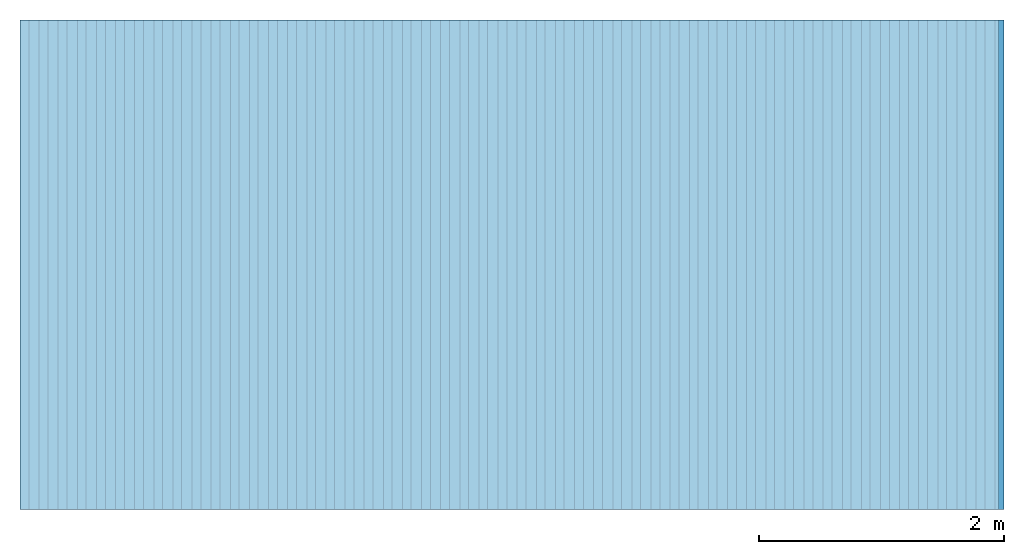
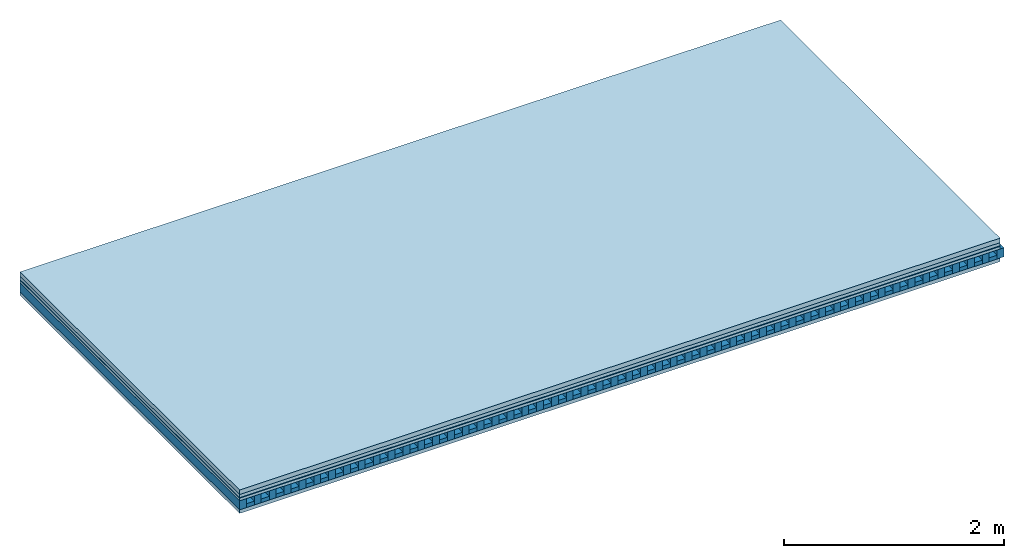
# One storey: 5 plates, 2 members, 1 element without a shape of its own.
"""IFC4 building model written with IfcOpenShell, lengths in metres."""

import ifcopenshell
import ifcopenshell.guid

model = None  # the IFC model being written
_history = None  # IfcOwnerHistory: only IFC2X3 demands one
_inside = {}  # id of a spatial element -> (the spatial element, [elements in it])
_under = {}  # id of a project, library or spatial element -> (it, [spatial elements below it])
_declared = {}  # id of a project -> (the project, [libraries it declares])
_typed = {}  # id of a type object -> (the type object, [elements of that type])
_made_of = {}  # id of a material, layer set ... -> (it, [elements and type objects made of it])


def new_model(schema):
    """Start an empty IFC model of exactly this schema.

    Asked for "IFC4X3", IfcOpenShell would pick the latest addendum, in which some entities
    have other attributes; the version numbers below select the first issue.
    IFC2X3 requires an IfcOwnerHistory on every rooted entity: one is made here for all.
    """
    global model, _history
    if schema == "IFC4X3":
        model = ifcopenshell.file(schema_version=(4, 3, 0, 0))
    else:
        model = ifcopenshell.file(schema=schema)
    _inside.clear()
    _under.clear()
    _declared.clear()
    _typed.clear()
    _made_of.clear()
    _history = None
    if model.schema == "IFC2X3":
        org = make("IfcOrganization", Name="unknown")
        user = make(
            "IfcPersonAndOrganization",
            ThePerson=make("IfcPerson", FamilyName="unknown"),
            TheOrganization=org,
        )
        app = make(
            "IfcApplication",
            ApplicationDeveloper=org,
            Version="unknown",
            ApplicationFullName="unknown",
            ApplicationIdentifier="unknown",
        )
        _history = make(
            "IfcOwnerHistory",
            OwningUser=user,
            OwningApplication=app,
            ChangeAction="ADDED",
            CreationDate=0,
        )
    return model


def make(cls, **values):
    """One entity of the class cls with the attributes given. An attribute that is None is left unset."""
    return model.create_entity(
        cls, **{name: value for name, value in values.items() if value is not None}
    )


def rooted(cls, **values):
    """An entity with a GlobalId (a new one), such as an element, a storey or a relation."""
    return make(cls, GlobalId=ifcopenshell.guid.new(), OwnerHistory=_history, **values)


def si_unit(unit_type, name, prefix=None):
    """IfcSIUnit, for example si_unit("LENGTHUNIT", "METRE", prefix="MILLI")."""
    return make("IfcSIUnit", UnitType=unit_type, Prefix=prefix, Name=name)


def derived_unit(unit_type, elements):
    """IfcDerivedUnit: a product of units, each with its exponent."""
    return make(
        "IfcDerivedUnit",
        Elements=[
            make("IfcDerivedUnitElement", Unit=unit, Exponent=power)
            for unit, power in elements
        ],
        UnitType=unit_type,
    )


def assignment(units):
    """IfcUnitAssignment: the units of a project."""
    return None if units is None else make("IfcUnitAssignment", Units=units)


def point(xyz):
    """IfcCartesianPoint."""
    return None if xyz is None else make("IfcCartesianPoint", Coordinates=xyz)


def direction(xyz):
    """IfcDirection."""
    return None if xyz is None else make("IfcDirection", DirectionRatios=xyz)


def frame(location, z_axis=None, x_axis=None):
    """IfcAxis2Placement3D, a coordinate frame: its origin and axes. An axis left out is left unset."""
    return make(
        "IfcAxis2Placement3D",
        Location=point(location),
        Axis=direction(z_axis),
        RefDirection=direction(x_axis),
    )


def frame_2d(location, x_axis=None):
    """IfcAxis2Placement2D, a coordinate frame in the plane: its origin and x axis."""
    return make(
        "IfcAxis2Placement2D", Location=point(location), RefDirection=direction(x_axis)
    )


def origin():
    """The frame at (0, 0, 0) with its axes left unset."""
    return frame((0.0, 0.0, 0.0))


def origin_with_axes():
    """The frame at (0, 0, 0) with the z axis (0, 0, 1) and the x axis (1, 0, 0) written out."""
    return frame((0.0, 0.0, 0.0), z_axis=(0.0, 0.0, 1.0), x_axis=(1.0, 0.0, 0.0))


def place(relative_to, where):
    """IfcLocalPlacement: puts the frame where relative to a parent placement (None: the world)."""
    return make(
        "IfcLocalPlacement", PlacementRelTo=relative_to, RelativePlacement=where
    )


def context(
    kind, dimensions, precision=None, world=None, true_north=None, identifier=None
):
    """IfcGeometricRepresentationContext, for example the 3D "Model" context."""
    return make(
        "IfcGeometricRepresentationContext",
        ContextIdentifier=identifier,
        ContextType=kind,
        CoordinateSpaceDimension=dimensions,
        Precision=precision,
        WorldCoordinateSystem=world,
        TrueNorth=true_north,
    )


def project(units=None, contexts=None):
    """IfcProject with its units and contexts."""
    return rooted(
        "IfcProject",
        Name="project",
        RepresentationContexts=contexts,
        UnitsInContext=assignment(units),
    )


def spatial(cls, under=None, at=None, **own):
    """A site, building, storey or space (cls), placed at a placement, below another one or the project."""
    s = rooted(cls, ObjectPlacement=at, **own)
    if under is not None:
        _under.setdefault(under.id(), (under, []))[1].append(s)
    return s


def profile(cls, at=None, kind="AREA", **sizes):
    """A parametric profile (cls). Its sizes go by their IFC names, for example OverallWidth=200.0."""
    return make(cls, ProfileType=kind, Position=at, **sizes)


def rectangle(**sizes):
    """IfcRectangleProfileDef."""
    return profile("IfcRectangleProfileDef", **sizes)


def extrude(swept, where, along, depth):
    """IfcExtrudedAreaSolid: the profile swept, set in the frame where, extruded along a direction by depth."""
    return make(
        "IfcExtrudedAreaSolid",
        SweptArea=swept,
        Position=where,
        ExtrudedDirection=direction(along),
        Depth=depth,
    )


def shape(context_of_items, identifier, shape_type, items):
    """IfcShapeRepresentation: the items that make up one representation, for example the "Body"."""
    return make(
        "IfcShapeRepresentation",
        ContextOfItems=context_of_items,
        RepresentationIdentifier=identifier,
        RepresentationType=shape_type,
        Items=items,
    )


def material(Name=None, Category=None):
    """IfcMaterial."""
    return make("IfcMaterial", Name=Name, Category=Category)


def layer(
    of_material, thickness, ventilated=None, Name=None, Category=None, Priority=None
):
    """IfcMaterialLayer: one layer of a wall or slab, of a material (None: an air gap)."""
    return make(
        "IfcMaterialLayer",
        Material=of_material,
        LayerThickness=thickness,
        IsVentilated=ventilated,
        Name=Name,
        Category=Category,
        Priority=Priority,
    )


def layer_set(layers, Name=None):
    """IfcMaterialLayerSet."""
    return make("IfcMaterialLayerSet", MaterialLayers=layers, LayerSetName=Name)


def made_of(thing, what):
    """Note that an element or type object is made of a material, layer set ...; save() writes the relation."""
    if what is not None:
        _made_of.setdefault(what.id(), (what, []))[1].append(thing)
    return thing


def type_object(cls, material=None, **own):
    """A type object (cls), such as IfcWallType, which elements share."""
    return made_of(rooted(cls, **own), material)


def element(
    cls,
    number,
    at=None,
    inside=None,
    cuts=None,
    type_object=None,
    material=None,
    context=None,
    identifier="Body",
    shape_type=None,
    held_by="IfcProductDefinitionShape",
    body=None,
    shapes=None,
    **own,
):
    """One element of the class cls, such as IfcWall. Its Tag is "e" and its number.

    at: its placement. inside: the storey or other place that contains it. cuts: it is an
    opening in that element (IfcRelVoidsElement). A single representation is given by context,
    identifier, shape_type and body (its items); several are given by shapes. held_by: the class
    of the entity that holds the representations. save() writes the other relations.
    """
    e = rooted(cls, Tag="e%d" % number, ObjectPlacement=at, **own)
    if body is not None:
        shapes = [shape(context, identifier, shape_type, body)]
    if shapes is not None:
        e.Representation = make(held_by, Representations=shapes)
    if inside is not None:
        _inside.setdefault(inside.id(), (inside, []))[1].append(e)
    if cuts is not None:
        rooted(
            "IfcRelVoidsElement", RelatingBuildingElement=cuts, RelatedOpeningElement=e
        )
    if type_object is not None:
        _typed.setdefault(type_object.id(), (type_object, []))[1].append(e)
    return made_of(e, material)


def aggregate(whole, parts):
    """IfcRelAggregates: a whole, such as a stair, and the parts it consists of."""
    return rooted("IfcRelAggregates", RelatingObject=whole, RelatedObjects=parts)


def save(model, path):
    """Write the relations noted so far, then the file.

    IfcRelAggregates (storeys below a building ...), IfcRelContainedInSpatialStructure (elements
    in a storey), IfcRelDefinesByType, IfcRelAssociatesMaterial and IfcRelDeclares: one each for
    every whole, place, type object, material and project.
    """
    for whole, parts in _under.values():
        aggregate(whole, parts)
    for where, things in _inside.values():
        rooted(
            "IfcRelContainedInSpatialStructure",
            RelatedElements=things,
            RelatingStructure=where,
        )
    for kind, things in _typed.values():
        rooted("IfcRelDefinesByType", RelatedObjects=things, RelatingType=kind)
    for what, things in _made_of.values():
        rooted("IfcRelAssociatesMaterial", RelatedObjects=things, RelatingMaterial=what)
    for by, libraries in _declared.values():
        rooted("IfcRelDeclares", RelatingContext=by, RelatedDefinitions=libraries)
    model.write(path)


model = new_model("IFC4")

# Units and contexts
plan_context = context("Plan", 3, precision=1e-05, world=origin(), true_north=direction((0.0, 1.0)))
model_context = context("Model", 3, precision=1e-05, world=origin(), true_north=direction((0.0, 1.0)))
ifc_project = project(units=[si_unit("LENGTHUNIT", "METRE"), derived_unit("SOUNDPRESSUREUNIT", [(si_unit("PRESSUREUNIT", "PASCAL", prefix="MICRO"), 0)]), si_unit("ENERGYUNIT", "JOULE", prefix="MEGA"), si_unit("MASSUNIT", "GRAM", prefix="KILO"), derived_unit("THERMALTRANSMITTANCEUNIT", [(si_unit("POWERUNIT", "WATT"), 1), (si_unit("AREAUNIT", "SQUARE_METRE"), -1), (si_unit("THERMODYNAMICTEMPERATUREUNIT", "KELVIN"), -1)]), derived_unit("AREADENSITYUNIT", [(si_unit("MASSUNIT", "GRAM", prefix="KILO"), 1), (si_unit("AREAUNIT", "SQUARE_METRE"), -1)]), derived_unit("USERDEFINED", [(si_unit("ENERGYUNIT", "JOULE", prefix="MEGA"), 1), (si_unit("AREAUNIT", "SQUARE_METRE"), -1)])], contexts=[plan_context, model_context])

# Site, building, storey
site = spatial("IfcSite", under=ifc_project)
building_placement = place(None, origin())
building = spatial("IfcBuilding", under=site, at=building_placement)
storey_placement = place(building_placement, origin())
storey = spatial("IfcBuildingStorey", under=building, at=storey_placement)

# Slab, members, plates
ifc_material_1 = material(Name="Cement screed", Category="04.006")
ifc_layer_1 = layer(ifc_material_1, 0.05, Name="On-material")
ifc_material_2 = material(Name="EP1, 35mm")
ifc_layer_2 = layer(ifc_material_2, 0.035, Name="Impact sound insulation")
ifc_material_3 = material(Name="Step 6mm", Category="10.009")
ifc_layer_3 = layer(ifc_material_3, 0.006, Name="Additional insulation")
ifc_material_4 = material()
ifc_layer_4 = layer(ifc_material_4, 0.03, Name="Sub-floor")
ifc_material_5 = material(Name="Rigid, of the art")
ifc_layer_5 = layer(ifc_material_5, 0.0, Name="Bond")
ifc_layer_6 = layer(None, 0.1, Name="Supporting structure")
ifc_layer_7 = layer(ifc_material_5, 0.0, Name="Bond")
ifc_material_6 = material(Name="panel on the underside HBF 40mm (20+20mm)", Category="07.001")
ifc_layer_8 = layer(ifc_material_6, 0.04, Name="Lower layer 1")
ifc_layer_set = layer_set([ifc_layer_1, ifc_layer_2, ifc_layer_3, ifc_layer_4, ifc_layer_5, ifc_layer_6, ifc_layer_7, ifc_layer_8])
slab_type = type_object("IfcSlabType", Name="A0088", PredefinedType="NOTDEFINED", material=ifc_layer_set)
slab_placement = place(None, frame((0.0, 0.0, 0.0), z_axis=(0.0, 0.0, -1.0), x_axis=(1.0, 0.0, 0.0)))
slab = element("IfcSlab", 1, at=slab_placement, inside=storey, type_object=slab_type, material=ifc_layer_set, Name="Slab #1")
ifc_material_7 = material(Name="Block Q4")
member_1_placement = place(slab_placement, origin())
member_1 = element("IfcMember", 2, at=member_1_placement, material=ifc_material_7, Name="Supporting structure", context=plan_context, shape_type="SweptSolid", body=[
    extrude(rectangle(XDim=0.071666666666667, YDim=0.1, at=frame_2d((0.0358333333333335, 0.05), x_axis=(1.0, 0.0))), frame((0.0, 4.0, 0.121), z_axis=(0.0, -1.0, 0.0), x_axis=(1.0, 0.0, 0.0)), (0.0, 0.0, 1.0), 4.0),
    extrude(rectangle(XDim=0.071666666666667, YDim=0.1, at=frame_2d((0.0358333333333335, 0.05), x_axis=(1.0, 0.0))), frame((0.15625, 4.0, 0.121), z_axis=(0.0, -1.0, 0.0), x_axis=(1.0, 0.0, 0.0)), (0.0, 0.0, 1.0), 4.0),
    extrude(rectangle(XDim=0.071666666666667, YDim=0.1, at=frame_2d((0.0358333333333335, 0.05), x_axis=(1.0, 0.0))), frame((0.3125, 4.0, 0.121), z_axis=(0.0, -1.0, 0.0), x_axis=(1.0, 0.0, 0.0)), (0.0, 0.0, 1.0), 4.0),
    extrude(rectangle(XDim=0.071666666666667, YDim=0.1, at=frame_2d((0.0358333333333335, 0.05), x_axis=(1.0, 0.0))), frame((0.46875, 4.0, 0.121), z_axis=(0.0, -1.0, 0.0), x_axis=(1.0, 0.0, 0.0)), (0.0, 0.0, 1.0), 4.0),
    extrude(rectangle(XDim=0.071666666666667, YDim=0.1, at=frame_2d((0.0358333333333335, 0.05), x_axis=(1.0, 0.0))), frame((0.625, 4.0, 0.121), z_axis=(0.0, -1.0, 0.0), x_axis=(1.0, 0.0, 0.0)), (0.0, 0.0, 1.0), 4.0),
    extrude(rectangle(XDim=0.071666666666667, YDim=0.1, at=frame_2d((0.0358333333333335, 0.05), x_axis=(1.0, 0.0))), frame((0.78125, 4.0, 0.121), z_axis=(0.0, -1.0, 0.0), x_axis=(1.0, 0.0, 0.0)), (0.0, 0.0, 1.0), 4.0),
    extrude(rectangle(XDim=0.071666666666667, YDim=0.1, at=frame_2d((0.0358333333333335, 0.05), x_axis=(1.0, 0.0))), frame((0.9375, 4.0, 0.121), z_axis=(0.0, -1.0, 0.0), x_axis=(1.0, 0.0, 0.0)), (0.0, 0.0, 1.0), 4.0),
    extrude(rectangle(XDim=0.071666666666667, YDim=0.1, at=frame_2d((0.0358333333333335, 0.05), x_axis=(1.0, 0.0))), frame((1.09375, 4.0, 0.121), z_axis=(0.0, -1.0, 0.0), x_axis=(1.0, 0.0, 0.0)), (0.0, 0.0, 1.0), 4.0),
    extrude(rectangle(XDim=0.071666666666667, YDim=0.1, at=frame_2d((0.0358333333333335, 0.05), x_axis=(1.0, 0.0))), frame((1.25, 4.0, 0.121), z_axis=(0.0, -1.0, 0.0), x_axis=(1.0, 0.0, 0.0)), (0.0, 0.0, 1.0), 4.0),
    extrude(rectangle(XDim=0.071666666666667, YDim=0.1, at=frame_2d((0.0358333333333335, 0.05), x_axis=(1.0, 0.0))), frame((1.40625, 4.0, 0.121), z_axis=(0.0, -1.0, 0.0), x_axis=(1.0, 0.0, 0.0)), (0.0, 0.0, 1.0), 4.0),
    extrude(rectangle(XDim=0.071666666666667, YDim=0.1, at=frame_2d((0.0358333333333335, 0.05), x_axis=(1.0, 0.0))), frame((1.5625, 4.0, 0.121), z_axis=(0.0, -1.0, 0.0), x_axis=(1.0, 0.0, 0.0)), (0.0, 0.0, 1.0), 4.0),
    extrude(rectangle(XDim=0.071666666666667, YDim=0.1, at=frame_2d((0.0358333333333335, 0.05), x_axis=(1.0, 0.0))), frame((1.71875, 4.0, 0.121), z_axis=(0.0, -1.0, 0.0), x_axis=(1.0, 0.0, 0.0)), (0.0, 0.0, 1.0), 4.0),
    extrude(rectangle(XDim=0.071666666666667, YDim=0.1, at=frame_2d((0.0358333333333335, 0.05), x_axis=(1.0, 0.0))), frame((1.875, 4.0, 0.121), z_axis=(0.0, -1.0, 0.0), x_axis=(1.0, 0.0, 0.0)), (0.0, 0.0, 1.0), 4.0),
    extrude(rectangle(XDim=0.071666666666667, YDim=0.1, at=frame_2d((0.0358333333333335, 0.05), x_axis=(1.0, 0.0))), frame((2.03125, 4.0, 0.121), z_axis=(0.0, -1.0, 0.0), x_axis=(1.0, 0.0, 0.0)), (0.0, 0.0, 1.0), 4.0),
    extrude(rectangle(XDim=0.071666666666667, YDim=0.1, at=frame_2d((0.0358333333333335, 0.05), x_axis=(1.0, 0.0))), frame((2.1875, 4.0, 0.121), z_axis=(0.0, -1.0, 0.0), x_axis=(1.0, 0.0, 0.0)), (0.0, 0.0, 1.0), 4.0),
    extrude(rectangle(XDim=0.071666666666667, YDim=0.1, at=frame_2d((0.0358333333333335, 0.05), x_axis=(1.0, 0.0))), frame((2.34375, 4.0, 0.121), z_axis=(0.0, -1.0, 0.0), x_axis=(1.0, 0.0, 0.0)), (0.0, 0.0, 1.0), 4.0),
    extrude(rectangle(XDim=0.071666666666667, YDim=0.1, at=frame_2d((0.0358333333333335, 0.05), x_axis=(1.0, 0.0))), frame((2.5, 4.0, 0.121), z_axis=(0.0, -1.0, 0.0), x_axis=(1.0, 0.0, 0.0)), (0.0, 0.0, 1.0), 4.0),
    extrude(rectangle(XDim=0.071666666666667, YDim=0.1, at=frame_2d((0.0358333333333335, 0.05), x_axis=(1.0, 0.0))), frame((2.65625, 4.0, 0.121), z_axis=(0.0, -1.0, 0.0), x_axis=(1.0, 0.0, 0.0)), (0.0, 0.0, 1.0), 4.0),
    extrude(rectangle(XDim=0.071666666666667, YDim=0.1, at=frame_2d((0.0358333333333335, 0.05), x_axis=(1.0, 0.0))), frame((2.8125, 4.0, 0.121), z_axis=(0.0, -1.0, 0.0), x_axis=(1.0, 0.0, 0.0)), (0.0, 0.0, 1.0), 4.0),
    extrude(rectangle(XDim=0.071666666666667, YDim=0.1, at=frame_2d((0.0358333333333335, 0.05), x_axis=(1.0, 0.0))), frame((2.96875, 4.0, 0.121), z_axis=(0.0, -1.0, 0.0), x_axis=(1.0, 0.0, 0.0)), (0.0, 0.0, 1.0), 4.0),
    extrude(rectangle(XDim=0.071666666666667, YDim=0.1, at=frame_2d((0.0358333333333335, 0.05), x_axis=(1.0, 0.0))), frame((3.125, 4.0, 0.121), z_axis=(0.0, -1.0, 0.0), x_axis=(1.0, 0.0, 0.0)), (0.0, 0.0, 1.0), 4.0),
    extrude(rectangle(XDim=0.071666666666667, YDim=0.1, at=frame_2d((0.0358333333333335, 0.05), x_axis=(1.0, 0.0))), frame((3.28125, 4.0, 0.121), z_axis=(0.0, -1.0, 0.0), x_axis=(1.0, 0.0, 0.0)), (0.0, 0.0, 1.0), 4.0),
    extrude(rectangle(XDim=0.071666666666667, YDim=0.1, at=frame_2d((0.0358333333333335, 0.05), x_axis=(1.0, 0.0))), frame((3.4375, 4.0, 0.121), z_axis=(0.0, -1.0, 0.0), x_axis=(1.0, 0.0, 0.0)), (0.0, 0.0, 1.0), 4.0),
    extrude(rectangle(XDim=0.071666666666667, YDim=0.1, at=frame_2d((0.0358333333333335, 0.05), x_axis=(1.0, 0.0))), frame((3.59375, 4.0, 0.121), z_axis=(0.0, -1.0, 0.0), x_axis=(1.0, 0.0, 0.0)), (0.0, 0.0, 1.0), 4.0),
    extrude(rectangle(XDim=0.071666666666667, YDim=0.1, at=frame_2d((0.0358333333333335, 0.05), x_axis=(1.0, 0.0))), frame((3.75, 4.0, 0.121), z_axis=(0.0, -1.0, 0.0), x_axis=(1.0, 0.0, 0.0)), (0.0, 0.0, 1.0), 4.0),
    extrude(rectangle(XDim=0.071666666666667, YDim=0.1, at=frame_2d((0.0358333333333335, 0.05), x_axis=(1.0, 0.0))), frame((3.90625, 4.0, 0.121), z_axis=(0.0, -1.0, 0.0), x_axis=(1.0, 0.0, 0.0)), (0.0, 0.0, 1.0), 4.0),
    extrude(rectangle(XDim=0.071666666666667, YDim=0.1, at=frame_2d((0.0358333333333335, 0.05), x_axis=(1.0, 0.0))), frame((4.0625, 4.0, 0.121), z_axis=(0.0, -1.0, 0.0), x_axis=(1.0, 0.0, 0.0)), (0.0, 0.0, 1.0), 4.0),
    extrude(rectangle(XDim=0.071666666666667, YDim=0.1, at=frame_2d((0.0358333333333335, 0.05), x_axis=(1.0, 0.0))), frame((4.21875, 4.0, 0.121), z_axis=(0.0, -1.0, 0.0), x_axis=(1.0, 0.0, 0.0)), (0.0, 0.0, 1.0), 4.0),
    extrude(rectangle(XDim=0.071666666666667, YDim=0.1, at=frame_2d((0.0358333333333335, 0.05), x_axis=(1.0, 0.0))), frame((4.375, 4.0, 0.121), z_axis=(0.0, -1.0, 0.0), x_axis=(1.0, 0.0, 0.0)), (0.0, 0.0, 1.0), 4.0),
    extrude(rectangle(XDim=0.071666666666667, YDim=0.1, at=frame_2d((0.0358333333333335, 0.05), x_axis=(1.0, 0.0))), frame((4.53125, 4.0, 0.121), z_axis=(0.0, -1.0, 0.0), x_axis=(1.0, 0.0, 0.0)), (0.0, 0.0, 1.0), 4.0),
    extrude(rectangle(XDim=0.071666666666667, YDim=0.1, at=frame_2d((0.0358333333333335, 0.05), x_axis=(1.0, 0.0))), frame((4.6875, 4.0, 0.121), z_axis=(0.0, -1.0, 0.0), x_axis=(1.0, 0.0, 0.0)), (0.0, 0.0, 1.0), 4.0),
    extrude(rectangle(XDim=0.071666666666667, YDim=0.1, at=frame_2d((0.0358333333333335, 0.05), x_axis=(1.0, 0.0))), frame((4.84375, 4.0, 0.121), z_axis=(0.0, -1.0, 0.0), x_axis=(1.0, 0.0, 0.0)), (0.0, 0.0, 1.0), 4.0),
    extrude(rectangle(XDim=0.071666666666667, YDim=0.1, at=frame_2d((0.0358333333333335, 0.05), x_axis=(1.0, 0.0))), frame((5.0, 4.0, 0.121), z_axis=(0.0, -1.0, 0.0), x_axis=(1.0, 0.0, 0.0)), (0.0, 0.0, 1.0), 4.0),
    extrude(rectangle(XDim=0.071666666666667, YDim=0.1, at=frame_2d((0.0358333333333335, 0.05), x_axis=(1.0, 0.0))), frame((5.15625, 4.0, 0.121), z_axis=(0.0, -1.0, 0.0), x_axis=(1.0, 0.0, 0.0)), (0.0, 0.0, 1.0), 4.0),
    extrude(rectangle(XDim=0.071666666666667, YDim=0.1, at=frame_2d((0.0358333333333335, 0.05), x_axis=(1.0, 0.0))), frame((5.3125, 4.0, 0.121), z_axis=(0.0, -1.0, 0.0), x_axis=(1.0, 0.0, 0.0)), (0.0, 0.0, 1.0), 4.0),
    extrude(rectangle(XDim=0.071666666666667, YDim=0.1, at=frame_2d((0.0358333333333335, 0.05), x_axis=(1.0, 0.0))), frame((5.46875, 4.0, 0.121), z_axis=(0.0, -1.0, 0.0), x_axis=(1.0, 0.0, 0.0)), (0.0, 0.0, 1.0), 4.0),
    extrude(rectangle(XDim=0.071666666666667, YDim=0.1, at=frame_2d((0.0358333333333335, 0.05), x_axis=(1.0, 0.0))), frame((5.625, 4.0, 0.121), z_axis=(0.0, -1.0, 0.0), x_axis=(1.0, 0.0, 0.0)), (0.0, 0.0, 1.0), 4.0),
    extrude(rectangle(XDim=0.071666666666667, YDim=0.1, at=frame_2d((0.0358333333333335, 0.05), x_axis=(1.0, 0.0))), frame((5.78125, 4.0, 0.121), z_axis=(0.0, -1.0, 0.0), x_axis=(1.0, 0.0, 0.0)), (0.0, 0.0, 1.0), 4.0),
    extrude(rectangle(XDim=0.071666666666667, YDim=0.1, at=frame_2d((0.0358333333333335, 0.05), x_axis=(1.0, 0.0))), frame((5.9375, 4.0, 0.121), z_axis=(0.0, -1.0, 0.0), x_axis=(1.0, 0.0, 0.0)), (0.0, 0.0, 1.0), 4.0),
    extrude(rectangle(XDim=0.071666666666667, YDim=0.1, at=frame_2d((0.0358333333333335, 0.05), x_axis=(1.0, 0.0))), frame((6.09375, 4.0, 0.121), z_axis=(0.0, -1.0, 0.0), x_axis=(1.0, 0.0, 0.0)), (0.0, 0.0, 1.0), 4.0),
    extrude(rectangle(XDim=0.071666666666667, YDim=0.1, at=frame_2d((0.0358333333333335, 0.05), x_axis=(1.0, 0.0))), frame((6.25, 4.0, 0.121), z_axis=(0.0, -1.0, 0.0), x_axis=(1.0, 0.0, 0.0)), (0.0, 0.0, 1.0), 4.0),
    extrude(rectangle(XDim=0.071666666666667, YDim=0.1, at=frame_2d((0.0358333333333335, 0.05), x_axis=(1.0, 0.0))), frame((6.40625, 4.0, 0.121), z_axis=(0.0, -1.0, 0.0), x_axis=(1.0, 0.0, 0.0)), (0.0, 0.0, 1.0), 4.0),
    extrude(rectangle(XDim=0.071666666666667, YDim=0.1, at=frame_2d((0.0358333333333335, 0.05), x_axis=(1.0, 0.0))), frame((6.5625, 4.0, 0.121), z_axis=(0.0, -1.0, 0.0), x_axis=(1.0, 0.0, 0.0)), (0.0, 0.0, 1.0), 4.0),
    extrude(rectangle(XDim=0.071666666666667, YDim=0.1, at=frame_2d((0.0358333333333335, 0.05), x_axis=(1.0, 0.0))), frame((6.71875, 4.0, 0.121), z_axis=(0.0, -1.0, 0.0), x_axis=(1.0, 0.0, 0.0)), (0.0, 0.0, 1.0), 4.0),
    extrude(rectangle(XDim=0.071666666666667, YDim=0.1, at=frame_2d((0.0358333333333335, 0.05), x_axis=(1.0, 0.0))), frame((6.875, 4.0, 0.121), z_axis=(0.0, -1.0, 0.0), x_axis=(1.0, 0.0, 0.0)), (0.0, 0.0, 1.0), 4.0),
    extrude(rectangle(XDim=0.071666666666667, YDim=0.1, at=frame_2d((0.0358333333333335, 0.05), x_axis=(1.0, 0.0))), frame((7.03125, 4.0, 0.121), z_axis=(0.0, -1.0, 0.0), x_axis=(1.0, 0.0, 0.0)), (0.0, 0.0, 1.0), 4.0),
    extrude(rectangle(XDim=0.071666666666667, YDim=0.1, at=frame_2d((0.0358333333333335, 0.05), x_axis=(1.0, 0.0))), frame((7.1875, 4.0, 0.121), z_axis=(0.0, -1.0, 0.0), x_axis=(1.0, 0.0, 0.0)), (0.0, 0.0, 1.0), 4.0),
    extrude(rectangle(XDim=0.071666666666667, YDim=0.1, at=frame_2d((0.0358333333333335, 0.05), x_axis=(1.0, 0.0))), frame((7.34375, 4.0, 0.121), z_axis=(0.0, -1.0, 0.0), x_axis=(1.0, 0.0, 0.0)), (0.0, 0.0, 1.0), 4.0),
    extrude(rectangle(XDim=0.071666666666667, YDim=0.1, at=frame_2d((0.0358333333333335, 0.05), x_axis=(1.0, 0.0))), frame((7.5, 4.0, 0.121), z_axis=(0.0, -1.0, 0.0), x_axis=(1.0, 0.0, 0.0)), (0.0, 0.0, 1.0), 4.0),
    extrude(rectangle(XDim=0.071666666666667, YDim=0.1, at=frame_2d((0.0358333333333335, 0.05), x_axis=(1.0, 0.0))), frame((7.65625, 4.0, 0.121), z_axis=(0.0, -1.0, 0.0), x_axis=(1.0, 0.0, 0.0)), (0.0, 0.0, 1.0), 4.0),
    extrude(rectangle(XDim=0.071666666666667, YDim=0.1, at=frame_2d((0.0358333333333335, 0.05), x_axis=(1.0, 0.0))), frame((7.8125, 4.0, 0.121), z_axis=(0.0, -1.0, 0.0), x_axis=(1.0, 0.0, 0.0)), (0.0, 0.0, 1.0), 4.0),
    extrude(rectangle(XDim=0.071666666666667, YDim=0.1, at=frame_2d((0.0358333333333335, 0.05), x_axis=(1.0, 0.0))), frame((7.96875, 4.0, 0.121), z_axis=(0.0, -1.0, 0.0), x_axis=(1.0, 0.0, 0.0)), (0.0, 0.0, 1.0), 4.0),
])
ifc_material_8 = material()
member_2_placement = place(slab_placement, origin())
member_2 = element("IfcMember", 3, at=member_2_placement, material=ifc_material_8, Name="in supporting structure", context=plan_context, shape_type="SweptSolid", body=[
    extrude(rectangle(XDim=0.084583333333333, YDim=0.042, at=frame_2d((0.0422916666666665, 0.021), x_axis=(1.0, 0.0))), frame((0.071666666666667, 4.0, 0.179), z_axis=(0.0, -1.0, 0.0), x_axis=(1.0, 0.0, 0.0)), (0.0, 0.0, 1.0), 4.0),
    extrude(rectangle(XDim=0.084583333333333, YDim=0.042, at=frame_2d((0.0422916666666665, 0.021), x_axis=(1.0, 0.0))), frame((0.227916666666667, 4.0, 0.179), z_axis=(0.0, -1.0, 0.0), x_axis=(1.0, 0.0, 0.0)), (0.0, 0.0, 1.0), 4.0),
    extrude(rectangle(XDim=0.084583333333333, YDim=0.042, at=frame_2d((0.0422916666666665, 0.021), x_axis=(1.0, 0.0))), frame((0.384166666666667, 4.0, 0.179), z_axis=(0.0, -1.0, 0.0), x_axis=(1.0, 0.0, 0.0)), (0.0, 0.0, 1.0), 4.0),
    extrude(rectangle(XDim=0.084583333333333, YDim=0.042, at=frame_2d((0.0422916666666665, 0.021), x_axis=(1.0, 0.0))), frame((0.540416666666667, 4.0, 0.179), z_axis=(0.0, -1.0, 0.0), x_axis=(1.0, 0.0, 0.0)), (0.0, 0.0, 1.0), 4.0),
    extrude(rectangle(XDim=0.084583333333333, YDim=0.042, at=frame_2d((0.0422916666666665, 0.021), x_axis=(1.0, 0.0))), frame((0.696666666666667, 4.0, 0.179), z_axis=(0.0, -1.0, 0.0), x_axis=(1.0, 0.0, 0.0)), (0.0, 0.0, 1.0), 4.0),
    extrude(rectangle(XDim=0.084583333333333, YDim=0.042, at=frame_2d((0.0422916666666665, 0.021), x_axis=(1.0, 0.0))), frame((0.852916666666667, 4.0, 0.179), z_axis=(0.0, -1.0, 0.0), x_axis=(1.0, 0.0, 0.0)), (0.0, 0.0, 1.0), 4.0),
    extrude(rectangle(XDim=0.084583333333333, YDim=0.042, at=frame_2d((0.0422916666666665, 0.021), x_axis=(1.0, 0.0))), frame((1.00916666666667, 4.0, 0.179), z_axis=(0.0, -1.0, 0.0), x_axis=(1.0, 0.0, 0.0)), (0.0, 0.0, 1.0), 4.0),
    extrude(rectangle(XDim=0.084583333333333, YDim=0.042, at=frame_2d((0.0422916666666665, 0.021), x_axis=(1.0, 0.0))), frame((1.16541666666667, 4.0, 0.179), z_axis=(0.0, -1.0, 0.0), x_axis=(1.0, 0.0, 0.0)), (0.0, 0.0, 1.0), 4.0),
    extrude(rectangle(XDim=0.084583333333333, YDim=0.042, at=frame_2d((0.0422916666666665, 0.021), x_axis=(1.0, 0.0))), frame((1.32166666666667, 4.0, 0.179), z_axis=(0.0, -1.0, 0.0), x_axis=(1.0, 0.0, 0.0)), (0.0, 0.0, 1.0), 4.0),
    extrude(rectangle(XDim=0.084583333333333, YDim=0.042, at=frame_2d((0.0422916666666665, 0.021), x_axis=(1.0, 0.0))), frame((1.47791666666667, 4.0, 0.179), z_axis=(0.0, -1.0, 0.0), x_axis=(1.0, 0.0, 0.0)), (0.0, 0.0, 1.0), 4.0),
    extrude(rectangle(XDim=0.084583333333333, YDim=0.042, at=frame_2d((0.0422916666666665, 0.021), x_axis=(1.0, 0.0))), frame((1.63416666666667, 4.0, 0.179), z_axis=(0.0, -1.0, 0.0), x_axis=(1.0, 0.0, 0.0)), (0.0, 0.0, 1.0), 4.0),
    extrude(rectangle(XDim=0.084583333333333, YDim=0.042, at=frame_2d((0.0422916666666665, 0.021), x_axis=(1.0, 0.0))), frame((1.79041666666667, 4.0, 0.179), z_axis=(0.0, -1.0, 0.0), x_axis=(1.0, 0.0, 0.0)), (0.0, 0.0, 1.0), 4.0),
    extrude(rectangle(XDim=0.084583333333333, YDim=0.042, at=frame_2d((0.0422916666666665, 0.021), x_axis=(1.0, 0.0))), frame((1.94666666666667, 4.0, 0.179), z_axis=(0.0, -1.0, 0.0), x_axis=(1.0, 0.0, 0.0)), (0.0, 0.0, 1.0), 4.0),
    extrude(rectangle(XDim=0.084583333333333, YDim=0.042, at=frame_2d((0.0422916666666665, 0.021), x_axis=(1.0, 0.0))), frame((2.10291666666667, 4.0, 0.179), z_axis=(0.0, -1.0, 0.0), x_axis=(1.0, 0.0, 0.0)), (0.0, 0.0, 1.0), 4.0),
    extrude(rectangle(XDim=0.084583333333333, YDim=0.042, at=frame_2d((0.0422916666666665, 0.021), x_axis=(1.0, 0.0))), frame((2.25916666666667, 4.0, 0.179), z_axis=(0.0, -1.0, 0.0), x_axis=(1.0, 0.0, 0.0)), (0.0, 0.0, 1.0), 4.0),
    extrude(rectangle(XDim=0.084583333333333, YDim=0.042, at=frame_2d((0.0422916666666665, 0.021), x_axis=(1.0, 0.0))), frame((2.41541666666667, 4.0, 0.179), z_axis=(0.0, -1.0, 0.0), x_axis=(1.0, 0.0, 0.0)), (0.0, 0.0, 1.0), 4.0),
    extrude(rectangle(XDim=0.084583333333333, YDim=0.042, at=frame_2d((0.0422916666666665, 0.021), x_axis=(1.0, 0.0))), frame((2.57166666666667, 4.0, 0.179), z_axis=(0.0, -1.0, 0.0), x_axis=(1.0, 0.0, 0.0)), (0.0, 0.0, 1.0), 4.0),
    extrude(rectangle(XDim=0.084583333333333, YDim=0.042, at=frame_2d((0.0422916666666665, 0.021), x_axis=(1.0, 0.0))), frame((2.72791666666667, 4.0, 0.179), z_axis=(0.0, -1.0, 0.0), x_axis=(1.0, 0.0, 0.0)), (0.0, 0.0, 1.0), 4.0),
    extrude(rectangle(XDim=0.084583333333333, YDim=0.042, at=frame_2d((0.0422916666666665, 0.021), x_axis=(1.0, 0.0))), frame((2.88416666666667, 4.0, 0.179), z_axis=(0.0, -1.0, 0.0), x_axis=(1.0, 0.0, 0.0)), (0.0, 0.0, 1.0), 4.0),
    extrude(rectangle(XDim=0.084583333333333, YDim=0.042, at=frame_2d((0.0422916666666665, 0.021), x_axis=(1.0, 0.0))), frame((3.04041666666667, 4.0, 0.179), z_axis=(0.0, -1.0, 0.0), x_axis=(1.0, 0.0, 0.0)), (0.0, 0.0, 1.0), 4.0),
    extrude(rectangle(XDim=0.084583333333333, YDim=0.042, at=frame_2d((0.0422916666666665, 0.021), x_axis=(1.0, 0.0))), frame((3.19666666666667, 4.0, 0.179), z_axis=(0.0, -1.0, 0.0), x_axis=(1.0, 0.0, 0.0)), (0.0, 0.0, 1.0), 4.0),
    extrude(rectangle(XDim=0.084583333333333, YDim=0.042, at=frame_2d((0.0422916666666665, 0.021), x_axis=(1.0, 0.0))), frame((3.35291666666667, 4.0, 0.179), z_axis=(0.0, -1.0, 0.0), x_axis=(1.0, 0.0, 0.0)), (0.0, 0.0, 1.0), 4.0),
    extrude(rectangle(XDim=0.084583333333333, YDim=0.042, at=frame_2d((0.0422916666666665, 0.021), x_axis=(1.0, 0.0))), frame((3.50916666666667, 4.0, 0.179), z_axis=(0.0, -1.0, 0.0), x_axis=(1.0, 0.0, 0.0)), (0.0, 0.0, 1.0), 4.0),
    extrude(rectangle(XDim=0.084583333333333, YDim=0.042, at=frame_2d((0.0422916666666665, 0.021), x_axis=(1.0, 0.0))), frame((3.66541666666667, 4.0, 0.179), z_axis=(0.0, -1.0, 0.0), x_axis=(1.0, 0.0, 0.0)), (0.0, 0.0, 1.0), 4.0),
    extrude(rectangle(XDim=0.084583333333333, YDim=0.042, at=frame_2d((0.0422916666666665, 0.021), x_axis=(1.0, 0.0))), frame((3.82166666666667, 4.0, 0.179), z_axis=(0.0, -1.0, 0.0), x_axis=(1.0, 0.0, 0.0)), (0.0, 0.0, 1.0), 4.0),
    extrude(rectangle(XDim=0.084583333333333, YDim=0.042, at=frame_2d((0.0422916666666665, 0.021), x_axis=(1.0, 0.0))), frame((3.97791666666667, 4.0, 0.179), z_axis=(0.0, -1.0, 0.0), x_axis=(1.0, 0.0, 0.0)), (0.0, 0.0, 1.0), 4.0),
    extrude(rectangle(XDim=0.084583333333333, YDim=0.042, at=frame_2d((0.0422916666666665, 0.021), x_axis=(1.0, 0.0))), frame((4.13416666666667, 4.0, 0.179), z_axis=(0.0, -1.0, 0.0), x_axis=(1.0, 0.0, 0.0)), (0.0, 0.0, 1.0), 4.0),
    extrude(rectangle(XDim=0.084583333333333, YDim=0.042, at=frame_2d((0.0422916666666665, 0.021), x_axis=(1.0, 0.0))), frame((4.29041666666667, 4.0, 0.179), z_axis=(0.0, -1.0, 0.0), x_axis=(1.0, 0.0, 0.0)), (0.0, 0.0, 1.0), 4.0),
    extrude(rectangle(XDim=0.084583333333333, YDim=0.042, at=frame_2d((0.0422916666666665, 0.021), x_axis=(1.0, 0.0))), frame((4.44666666666667, 4.0, 0.179), z_axis=(0.0, -1.0, 0.0), x_axis=(1.0, 0.0, 0.0)), (0.0, 0.0, 1.0), 4.0),
    extrude(rectangle(XDim=0.084583333333333, YDim=0.042, at=frame_2d((0.0422916666666665, 0.021), x_axis=(1.0, 0.0))), frame((4.60291666666667, 4.0, 0.179), z_axis=(0.0, -1.0, 0.0), x_axis=(1.0, 0.0, 0.0)), (0.0, 0.0, 1.0), 4.0),
    extrude(rectangle(XDim=0.084583333333333, YDim=0.042, at=frame_2d((0.0422916666666665, 0.021), x_axis=(1.0, 0.0))), frame((4.75916666666667, 4.0, 0.179), z_axis=(0.0, -1.0, 0.0), x_axis=(1.0, 0.0, 0.0)), (0.0, 0.0, 1.0), 4.0),
    extrude(rectangle(XDim=0.084583333333333, YDim=0.042, at=frame_2d((0.0422916666666665, 0.021), x_axis=(1.0, 0.0))), frame((4.91541666666667, 4.0, 0.179), z_axis=(0.0, -1.0, 0.0), x_axis=(1.0, 0.0, 0.0)), (0.0, 0.0, 1.0), 4.0),
    extrude(rectangle(XDim=0.084583333333333, YDim=0.042, at=frame_2d((0.0422916666666665, 0.021), x_axis=(1.0, 0.0))), frame((5.07166666666667, 4.0, 0.179), z_axis=(0.0, -1.0, 0.0), x_axis=(1.0, 0.0, 0.0)), (0.0, 0.0, 1.0), 4.0),
    extrude(rectangle(XDim=0.084583333333333, YDim=0.042, at=frame_2d((0.0422916666666665, 0.021), x_axis=(1.0, 0.0))), frame((5.22791666666667, 4.0, 0.179), z_axis=(0.0, -1.0, 0.0), x_axis=(1.0, 0.0, 0.0)), (0.0, 0.0, 1.0), 4.0),
    extrude(rectangle(XDim=0.084583333333333, YDim=0.042, at=frame_2d((0.0422916666666665, 0.021), x_axis=(1.0, 0.0))), frame((5.38416666666667, 4.0, 0.179), z_axis=(0.0, -1.0, 0.0), x_axis=(1.0, 0.0, 0.0)), (0.0, 0.0, 1.0), 4.0),
    extrude(rectangle(XDim=0.084583333333333, YDim=0.042, at=frame_2d((0.0422916666666665, 0.021), x_axis=(1.0, 0.0))), frame((5.54041666666667, 4.0, 0.179), z_axis=(0.0, -1.0, 0.0), x_axis=(1.0, 0.0, 0.0)), (0.0, 0.0, 1.0), 4.0),
    extrude(rectangle(XDim=0.084583333333333, YDim=0.042, at=frame_2d((0.0422916666666665, 0.021), x_axis=(1.0, 0.0))), frame((5.69666666666667, 4.0, 0.179), z_axis=(0.0, -1.0, 0.0), x_axis=(1.0, 0.0, 0.0)), (0.0, 0.0, 1.0), 4.0),
    extrude(rectangle(XDim=0.084583333333333, YDim=0.042, at=frame_2d((0.0422916666666665, 0.021), x_axis=(1.0, 0.0))), frame((5.85291666666667, 4.0, 0.179), z_axis=(0.0, -1.0, 0.0), x_axis=(1.0, 0.0, 0.0)), (0.0, 0.0, 1.0), 4.0),
    extrude(rectangle(XDim=0.084583333333333, YDim=0.042, at=frame_2d((0.0422916666666665, 0.021), x_axis=(1.0, 0.0))), frame((6.00916666666667, 4.0, 0.179), z_axis=(0.0, -1.0, 0.0), x_axis=(1.0, 0.0, 0.0)), (0.0, 0.0, 1.0), 4.0),
    extrude(rectangle(XDim=0.084583333333333, YDim=0.042, at=frame_2d((0.0422916666666665, 0.021), x_axis=(1.0, 0.0))), frame((6.16541666666667, 4.0, 0.179), z_axis=(0.0, -1.0, 0.0), x_axis=(1.0, 0.0, 0.0)), (0.0, 0.0, 1.0), 4.0),
    extrude(rectangle(XDim=0.084583333333333, YDim=0.042, at=frame_2d((0.0422916666666665, 0.021), x_axis=(1.0, 0.0))), frame((6.32166666666667, 4.0, 0.179), z_axis=(0.0, -1.0, 0.0), x_axis=(1.0, 0.0, 0.0)), (0.0, 0.0, 1.0), 4.0),
    extrude(rectangle(XDim=0.084583333333333, YDim=0.042, at=frame_2d((0.0422916666666665, 0.021), x_axis=(1.0, 0.0))), frame((6.47791666666667, 4.0, 0.179), z_axis=(0.0, -1.0, 0.0), x_axis=(1.0, 0.0, 0.0)), (0.0, 0.0, 1.0), 4.0),
    extrude(rectangle(XDim=0.084583333333333, YDim=0.042, at=frame_2d((0.0422916666666665, 0.021), x_axis=(1.0, 0.0))), frame((6.63416666666667, 4.0, 0.179), z_axis=(0.0, -1.0, 0.0), x_axis=(1.0, 0.0, 0.0)), (0.0, 0.0, 1.0), 4.0),
    extrude(rectangle(XDim=0.084583333333333, YDim=0.042, at=frame_2d((0.0422916666666665, 0.021), x_axis=(1.0, 0.0))), frame((6.79041666666667, 4.0, 0.179), z_axis=(0.0, -1.0, 0.0), x_axis=(1.0, 0.0, 0.0)), (0.0, 0.0, 1.0), 4.0),
    extrude(rectangle(XDim=0.084583333333333, YDim=0.042, at=frame_2d((0.0422916666666665, 0.021), x_axis=(1.0, 0.0))), frame((6.94666666666667, 4.0, 0.179), z_axis=(0.0, -1.0, 0.0), x_axis=(1.0, 0.0, 0.0)), (0.0, 0.0, 1.0), 4.0),
    extrude(rectangle(XDim=0.084583333333333, YDim=0.042, at=frame_2d((0.0422916666666665, 0.021), x_axis=(1.0, 0.0))), frame((7.10291666666667, 4.0, 0.179), z_axis=(0.0, -1.0, 0.0), x_axis=(1.0, 0.0, 0.0)), (0.0, 0.0, 1.0), 4.0),
    extrude(rectangle(XDim=0.084583333333333, YDim=0.042, at=frame_2d((0.0422916666666665, 0.021), x_axis=(1.0, 0.0))), frame((7.25916666666667, 4.0, 0.179), z_axis=(0.0, -1.0, 0.0), x_axis=(1.0, 0.0, 0.0)), (0.0, 0.0, 1.0), 4.0),
    extrude(rectangle(XDim=0.084583333333333, YDim=0.042, at=frame_2d((0.0422916666666665, 0.021), x_axis=(1.0, 0.0))), frame((7.41541666666667, 4.0, 0.179), z_axis=(0.0, -1.0, 0.0), x_axis=(1.0, 0.0, 0.0)), (0.0, 0.0, 1.0), 4.0),
    extrude(rectangle(XDim=0.084583333333333, YDim=0.042, at=frame_2d((0.0422916666666665, 0.021), x_axis=(1.0, 0.0))), frame((7.57166666666667, 4.0, 0.179), z_axis=(0.0, -1.0, 0.0), x_axis=(1.0, 0.0, 0.0)), (0.0, 0.0, 1.0), 4.0),
    extrude(rectangle(XDim=0.084583333333333, YDim=0.042, at=frame_2d((0.0422916666666665, 0.021), x_axis=(1.0, 0.0))), frame((7.72791666666667, 4.0, 0.179), z_axis=(0.0, -1.0, 0.0), x_axis=(1.0, 0.0, 0.0)), (0.0, 0.0, 1.0), 4.0),
    extrude(rectangle(XDim=0.084583333333333, YDim=0.042, at=frame_2d((0.0422916666666665, 0.021), x_axis=(1.0, 0.0))), frame((7.88416666666667, 4.0, 0.179), z_axis=(0.0, -1.0, 0.0), x_axis=(1.0, 0.0, 0.0)), (0.0, 0.0, 1.0), 4.0),
])
plate_1_placement = place(slab_placement, origin())
plate_1 = element("IfcPlate", 4, at=plate_1_placement, material=ifc_material_1, Name="On-material", context=plan_context, shape_type="SweptSolid", body=[
    extrude(rectangle(XDim=8.0, YDim=4.0, at=frame_2d((4.0, 2.0), x_axis=(1.0, 0.0))), origin_with_axes(), (0.0, 0.0, 1.0), 0.05),
])
plate_2_placement = place(slab_placement, origin())
plate_2 = element("IfcPlate", 5, at=plate_2_placement, material=ifc_material_2, Name="Impact sound insulation", context=plan_context, shape_type="SweptSolid", body=[
    extrude(rectangle(XDim=8.0, YDim=4.0, at=frame_2d((4.0, 2.0), x_axis=(1.0, 0.0))), frame((0.0, 0.0, 0.05), z_axis=(0.0, 0.0, 1.0), x_axis=(1.0, 0.0, 0.0)), (0.0, 0.0, 1.0), 0.035),
])
plate_3_placement = place(slab_placement, origin())
plate_3 = element("IfcPlate", 6, at=plate_3_placement, material=ifc_material_3, Name="Additional insulation", context=plan_context, shape_type="SweptSolid", body=[
    extrude(rectangle(XDim=8.0, YDim=4.0, at=frame_2d((4.0, 2.0), x_axis=(1.0, 0.0))), frame((0.0, 0.0, 0.085), z_axis=(0.0, 0.0, 1.0), x_axis=(1.0, 0.0, 0.0)), (0.0, 0.0, 1.0), 0.006),
])
plate_4_placement = place(slab_placement, origin())
plate_4 = element("IfcPlate", 7, at=plate_4_placement, material=ifc_material_4, Name="Sub-floor", context=plan_context, shape_type="SweptSolid", body=[
    extrude(rectangle(XDim=8.0, YDim=4.0, at=frame_2d((4.0, 2.0), x_axis=(1.0, 0.0))), frame((0.0, 0.0, 0.091), z_axis=(0.0, 0.0, 1.0), x_axis=(1.0, 0.0, 0.0)), (0.0, 0.0, 1.0), 0.03),
])
plate_5_placement = place(slab_placement, origin())
plate_5 = element("IfcPlate", 8, at=plate_5_placement, material=ifc_material_6, Name="Lower layer 1", context=plan_context, shape_type="SweptSolid", body=[
    extrude(rectangle(XDim=8.0, YDim=4.0, at=frame_2d((4.0, 2.0), x_axis=(1.0, 0.0))), frame((0.0, 0.0, 0.221), z_axis=(0.0, 0.0, 1.0), x_axis=(1.0, 0.0, 0.0)), (0.0, 0.0, 1.0), 0.04),
])
aggregate(slab, [plate_1, plate_2, plate_3, plate_4, member_1, member_2, plate_5])

save(model, "model.ifc")
